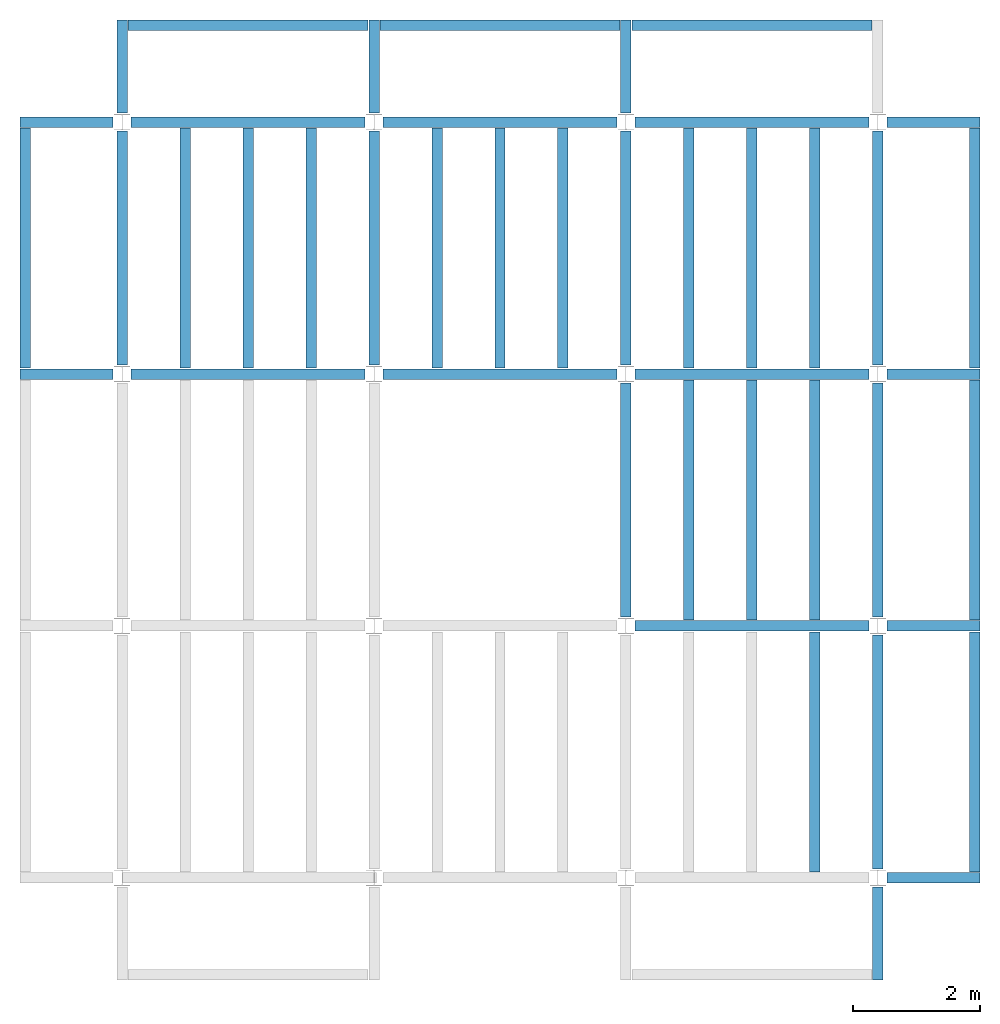
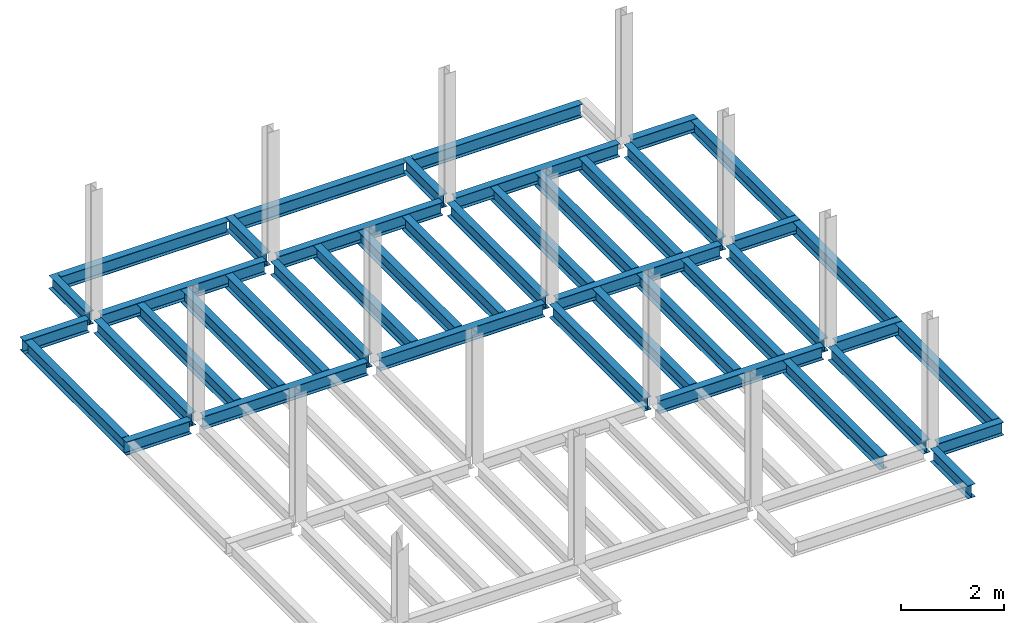
# One storey, part 2 of 3: 44 beams, 5 elements without a shape of their own.
"""IFC4 building model written with IfcOpenShell, lengths in feet."""

from ifc_helpers import new_model, entity, si_unit, converted_unit, derived_unit, direction, frame, origin, place, context, subcontext, project, spatial, line, arc, indexed_curve, outline, extrude, source, transform, mapped, material, type_object, type_shapes, element, aggregate, save


model = new_model("IFC4")

# Units and contexts
model_context = context("Model", 3, precision=0.0001, world=origin(), true_north=direction((6.123233995736766e-17, 1.0)))
plan_context = context("Plan", 3, precision=0.0001, world=origin(), true_north=direction((6.123233995736766e-17, 1.0)))
body_context = subcontext(model_context, "Body", "Model", "MODEL_VIEW")
ifc_project = project(units=[converted_unit("LENGTHUNIT", "FOOT", entity("IfcLengthMeasure", 0.3048), si_unit("LENGTHUNIT", "METRE"), dimensions=[1, 0, 0, 0, 0, 0, 0]), converted_unit("AREAUNIT", "SQUARE FOOT", entity("IfcAreaMeasure", 0.09290304), si_unit("AREAUNIT", "SQUARE_METRE"), dimensions=[2, 0, 0, 0, 0, 0, 0]), converted_unit("PLANEANGLEUNIT", "DEGREE", entity("IfcPlaneAngleMeasure", 0.017453292519943278), si_unit("PLANEANGLEUNIT", "RADIAN"), dimensions=[0, 0, 0, 0, 0, 0, 0]), converted_unit("VOLUMEUNIT", "CUBIC FOOT", entity("IfcVolumeMeasure", 0.028316846592000004), si_unit("VOLUMEUNIT", "CUBIC_METRE"), dimensions=[3, 0, 0, 0, 0, 0, 0]), si_unit("PRESSUREUNIT", "PASCAL"), derived_unit("MASSDENSITYUNIT", [(si_unit("MASSUNIT", "GRAM", prefix="KILO"), 1), (si_unit("LENGTHUNIT", "METRE"), -3)]), derived_unit("VAPORPERMEABILITYUNIT", [(si_unit("LENGTHUNIT", "METRE"), -1), (si_unit("TIMEUNIT", "SECOND"), 1)]), derived_unit("USERDEFINED", [(si_unit("MASSUNIT", "GRAM", prefix="KILO"), 1), (si_unit("LENGTHUNIT", "METRE"), 3), (si_unit("TIMEUNIT", "SECOND"), -3), (si_unit("ELECTRICCURRENTUNIT", "AMPERE"), -2)]), derived_unit("MODULUSOFELASTICITYUNIT", [(si_unit("MASSUNIT", "GRAM", prefix="KILO"), 1), (si_unit("LENGTHUNIT", "METRE"), -1), (si_unit("TIMEUNIT", "SECOND"), -2)]), derived_unit("THERMALEXPANSIONCOEFFICIENTUNIT", [(si_unit("THERMODYNAMICTEMPERATUREUNIT", "KELVIN"), -1)]), derived_unit("SPECIFICHEATCAPACITYUNIT", [(si_unit("TIMEUNIT", "SECOND"), -2), (si_unit("THERMODYNAMICTEMPERATUREUNIT", "KELVIN"), -1), (si_unit("LENGTHUNIT", "METRE"), 2)]), derived_unit("THERMALCONDUCTANCEUNIT", [(si_unit("MASSUNIT", "GRAM", prefix="KILO"), 1), (si_unit("TIMEUNIT", "SECOND"), -3), (si_unit("THERMODYNAMICTEMPERATUREUNIT", "KELVIN"), -1), (si_unit("LENGTHUNIT", "METRE"), 1)])], contexts=[model_context, plan_context])

# Site, building, storey
site_placement = place(None, origin())
site = spatial("IfcSite", under=ifc_project, at=site_placement, CompositionType="ELEMENT")
building_placement = place(site_placement, origin())
building = spatial("IfcBuilding", under=site, at=building_placement, CompositionType="ELEMENT")
storey_placement = place(building_placement, frame((0.0, 0.0, 29.875)))
storey = spatial("IfcBuildingStorey", under=building, at=storey_placement, Name="STR 04", CompositionType="ELEMENT", Elevation=29.875)

# Beams
ifc_material = material(Name="Steel ASTM A992", Category="Metal")
beam_type_1 = type_object("IfcBeamType", Name="W12X26", PredefinedType="JOIST", material=ifc_material)
shared_shape_1 = source(origin(), body_context, "Body", "SweptSolid", [
    extrude(outline(indexed_curve([(-0.27041666666666714, -0.47666666666666574), (-0.27041666666666714, -0.5083333333333351), (0.2704166666666669, -0.5083333333333351), (0.2704166666666669, -0.47666666666666574), (0.03458333333333309, -0.47666666666666574), (0.016905663803669493, -0.46934433619632937), (0.009583333333333202, -0.4516666666666659), (0.0095833333333332, 0.45166666666666705), (0.01690566380366948, 0.4693443361963307), (0.03458333333333325, 0.4766666666666671), (0.2704166666666669, 0.4766666666666671), (0.2704166666666669, 0.5083333333333312), (-0.2704166666666655, 0.5083333333333312), (-0.2704166666666655, 0.4766666666666671), (-0.034583333333333514, 0.47666666666666707), (-0.016905663803669865, 0.46934433619633054), (-0.009583333333333737, 0.45166666666666694), (-0.009583333333333735, -0.4516666666666658), (-0.01690566380367013, -0.4693443361963295), (-0.03458333333333368, -0.47666666666666574)], segments=[line(1, 2, 3, 4, 5), arc(5, 6, 7), line(7, 8), arc(8, 9, 10), line(10, 11, 12, 13, 14, 15), arc(15, 16, 17), line(17, 18), arc(18, 19, 20), line(20, 1)], self_intersect=False)), frame((-6.103346456692914, 0.0, 0.0), z_axis=(-1.0, 0.0, 0.0), x_axis=(0.0, -1.0, 0.0)), (0.0, 0.0, -1.0), 12.083333333333323),
])
type_shapes(beam_type_1, [shared_shape_1])
for number, where, name in (
    (1, (6.561679790026307, 39.0, -0.5083333333333329), "W12X26"),
    (2, (6.561679790026288, 26.0, -0.5083333333333329), "W12X26"),
):
    element("IfcBeam", number, at=place(storey_placement, frame(where)), inside=storey, type_object=beam_type_1, material=ifc_material, Name=name, ObjectType="W Shapes:W12X26", PredefinedType="JOIST", context=body_context, shape_type="MappedRepresentation", body=[
        mapped(shared_shape_1, transform((0.0, 0.0, 0.0), scale=1.0)),
    ])
beam_1_placement = place(storey_placement, frame((39.0, 6.56167979002612, -0.5083333333333329), z_axis=(0.0, 0.0, 1.0), x_axis=(0.0, 1.0, 0.0)))
element("IfcBeam", 3, at=beam_1_placement, inside=storey, type_object=beam_type_1, material=ifc_material, Name="W12X26", ObjectType="W Shapes:W12X26", PredefinedType="JOIST", context=body_context, shape_type="MappedRepresentation", body=[
    mapped(shared_shape_1, transform((0.0, 0.0, 0.0), scale=1.0)),
])
beam_type_2 = type_object("IfcBeamType", Name="W12X26", PredefinedType="JOIST", material=ifc_material)
shared_shape_2 = source(origin(), body_context, "Body", "SweptSolid", [
    extrude(outline(indexed_curve([(-0.27041666666666714, -0.47666666666666574), (-0.27041666666666714, -0.5083333333333351), (0.2704166666666669, -0.5083333333333351), (0.2704166666666669, -0.47666666666666574), (0.03458333333333309, -0.47666666666666574), (0.016905663803669493, -0.46934433619632937), (0.009583333333333202, -0.4516666666666659), (0.0095833333333332, 0.45166666666666705), (0.01690566380366948, 0.4693443361963307), (0.03458333333333325, 0.4766666666666671), (0.2704166666666669, 0.4766666666666671), (0.2704166666666669, 0.5083333333333312), (-0.2704166666666655, 0.5083333333333312), (-0.2704166666666655, 0.4766666666666671), (-0.034583333333333514, 0.47666666666666707), (-0.016905663803669865, 0.46934433619633054), (-0.009583333333333737, 0.45166666666666694), (-0.009583333333333735, -0.4516666666666658), (-0.01690566380367013, -0.4693443361963295), (-0.03458333333333368, -0.47666666666666574)], segments=[line(1, 2, 3, 4, 5), arc(5, 6, 7), line(7, 8), arc(8, 9, 10), line(10, 11, 12, 13, 14, 15), arc(15, 16, 17), line(17, 18), arc(18, 19, 20), line(20, 1)], self_intersect=False)), frame((-6.226706036745409, 0.0, 0.0), z_axis=(-1.0, 0.0, 0.0), x_axis=(0.0, -1.0, 0.0)), (0.0, 0.0, -1.0), 12.08333333333333),
])
type_shapes(beam_type_2, [shared_shape_2])
for number, where, name in (
    (4, (19.685039370078798, 39.0, -0.5083333333333329), "W12X26"),
    (5, (19.68503937007878, 26.0, -0.5083333333333329), "W12X26"),
):
    element("IfcBeam", number, at=place(storey_placement, frame(where)), inside=storey, type_object=beam_type_2, material=ifc_material, Name=name, ObjectType="W Shapes:W12X26", PredefinedType="JOIST", context=body_context, shape_type="MappedRepresentation", body=[
        mapped(shared_shape_2, transform((0.0, 0.0, 0.0), scale=1.0)),
    ])
for number, where, z_axis, x_axis, name in (
    (6, (39.0, 19.685039370078613, -0.5083333333333329), (0.0, 0.0, 1.0), (0.0, 1.0, 0.0), "W12X26"),
    (7, (26.0, 19.685039370078655, -0.5083333333333329), (0.0, 0.0, 1.0), (0.0, 1.0, 0.0), "W12X26"),
):
    element("IfcBeam", number, at=place(storey_placement, frame(where, z_axis=z_axis, x_axis=x_axis)), inside=storey, type_object=beam_type_2, material=ifc_material, Name=name, ObjectType="W Shapes:W12X26", PredefinedType="JOIST", context=body_context, shape_type="MappedRepresentation", body=[
        mapped(shared_shape_2, transform((0.0, 0.0, 0.0), scale=1.0)),
    ])

# Assembly, beams
assembly_1_placement = place(storey_placement, origin())
assembly_1 = element("IfcElementAssembly", 8, at=assembly_1_placement, inside=storey, Name="Structural Framing System", ObjectType="Structural Beam System:Structural Framing System", AssemblyPlace="NOTDEFINED", PredefinedType="BEAM_GRID")
beam_type_3 = type_object("IfcBeamType", Name="W12X26", PredefinedType="JOIST", material=ifc_material)
shared_shape_3 = source(origin(), body_context, "Body", "SweptSolid", [
    extrude(outline(indexed_curve([(-0.27041666666666714, -0.47666666666666574), (-0.27041666666666714, -0.5083333333333351), (0.2704166666666669, -0.5083333333333351), (0.2704166666666669, -0.47666666666666574), (0.03458333333333309, -0.47666666666666574), (0.016905663803669493, -0.46934433619632937), (0.009583333333333202, -0.4516666666666659), (0.0095833333333332, 0.45166666666666705), (0.01690566380366948, 0.4693443361963307), (0.03458333333333325, 0.4766666666666671), (0.2704166666666669, 0.4766666666666671), (0.2704166666666669, 0.5083333333333312), (-0.2704166666666655, 0.5083333333333312), (-0.2704166666666655, 0.4766666666666671), (-0.034583333333333514, 0.47666666666666707), (-0.016905663803669865, 0.46934433619633054), (-0.009583333333333737, 0.45166666666666694), (-0.009583333333333735, -0.4516666666666658), (-0.01690566380367013, -0.4693443361963295), (-0.03458333333333368, -0.47666666666666574)], segments=[line(1, 2, 3, 4, 5), arc(5, 6, 7), line(7, 8), arc(8, 9, 10), line(10, 11, 12, 13, 14, 15), arc(15, 16, 17), line(17, 18), arc(18, 19, 20), line(20, 1)], self_intersect=False)), frame((-6.187916666666566, 0.0, 0.0), z_axis=(-1.0, 0.0, 0.0), x_axis=(0.0, -1.0, 0.0)), (0.0, 0.0, -1.0), 12.375833333333075),
])
type_shapes(beam_type_3, [shared_shape_3])
beam_2_placement = place(assembly_1_placement, frame((3.250000000000073, 32.49999999999969, -0.5083333333333329), z_axis=(0.0, 0.0, 1.0), x_axis=(0.0, 1.0, 0.0)))
beam_2 = element("IfcBeam", 9, at=beam_2_placement, type_object=beam_type_3, material=ifc_material, Name="W12X26", ObjectType="W Shapes:W12X26", PredefinedType="JOIST", context=body_context, shape_type="MappedRepresentation", body=[
    mapped(shared_shape_3, transform((0.0, 0.0, 0.0), scale=1.0)),
])
beam_3_placement = place(assembly_1_placement, frame((6.500000000000094, 32.49999999999967, -0.5083333333333329), z_axis=(0.0, 0.0, 1.0), x_axis=(0.0, 1.0, 0.0)))
beam_3 = element("IfcBeam", 10, at=beam_3_placement, type_object=beam_type_3, material=ifc_material, Name="W12X26", ObjectType="W Shapes:W12X26", PredefinedType="JOIST", context=body_context, shape_type="MappedRepresentation", body=[
    mapped(shared_shape_3, transform((0.0, 0.0, 0.0), scale=1.0)),
])
beam_4_placement = place(assembly_1_placement, frame((9.750000000000115, 32.49999999999966, -0.5083333333333329), z_axis=(0.0, 0.0, 1.0), x_axis=(0.0, 1.0, 0.0)))
beam_4 = element("IfcBeam", 11, at=beam_4_placement, type_object=beam_type_3, material=ifc_material, Name="W12X26", ObjectType="W Shapes:W12X26", PredefinedType="JOIST", context=body_context, shape_type="MappedRepresentation", body=[
    mapped(shared_shape_3, transform((0.0, 0.0, 0.0), scale=1.0)),
])
aggregate(assembly_1, [beam_2, beam_3, beam_4])

assembly_2_placement = place(storey_placement, origin())
assembly_2 = element("IfcElementAssembly", 12, at=assembly_2_placement, inside=storey, Name="Structural Framing System", ObjectType="Structural Beam System:Structural Framing System", AssemblyPlace="NOTDEFINED", PredefinedType="BEAM_GRID")
beam_5_placement = place(assembly_2_placement, frame((16.25000000000014, 32.499999999999645, -0.5083333333333329), z_axis=(0.0, 0.0, 1.0), x_axis=(0.0, 1.0, 0.0)))
beam_5 = element("IfcBeam", 13, at=beam_5_placement, type_object=beam_type_3, material=ifc_material, Name="W12X26", ObjectType="W Shapes:W12X26", PredefinedType="JOIST", context=body_context, shape_type="MappedRepresentation", body=[
    mapped(shared_shape_3, transform((0.0, 0.0, 0.0), scale=1.0)),
])
beam_6_placement = place(assembly_2_placement, frame((19.50000000000014, 32.49999999999963, -0.5083333333333329), z_axis=(0.0, 0.0, 1.0), x_axis=(0.0, 1.0, 0.0)))
beam_6 = element("IfcBeam", 14, at=beam_6_placement, type_object=beam_type_3, material=ifc_material, Name="W12X26", ObjectType="W Shapes:W12X26", PredefinedType="JOIST", context=body_context, shape_type="MappedRepresentation", body=[
    mapped(shared_shape_3, transform((0.0, 0.0, 0.0), scale=1.0)),
])
beam_7_placement = place(assembly_2_placement, frame((22.750000000000142, 32.499999999999616, -0.5083333333333329), z_axis=(0.0, 0.0, 1.0), x_axis=(0.0, 1.0, 0.0)))
beam_7 = element("IfcBeam", 15, at=beam_7_placement, type_object=beam_type_3, material=ifc_material, Name="W12X26", ObjectType="W Shapes:W12X26", PredefinedType="JOIST", context=body_context, shape_type="MappedRepresentation", body=[
    mapped(shared_shape_3, transform((0.0, 0.0, 0.0), scale=1.0)),
])
aggregate(assembly_2, [beam_5, beam_6, beam_7])

# Assembly, beam
assembly_3_placement = place(storey_placement, origin())
assembly_3 = element("IfcElementAssembly", 16, at=assembly_3_placement, inside=storey, Name="Structural Framing System", ObjectType="Structural Beam System:Structural Framing System", AssemblyPlace="NOTDEFINED", PredefinedType="BEAM_GRID")
beam_8_placement = place(assembly_3_placement, frame((35.7500000000001, 6.499999999999728, -0.5083333333333329), z_axis=(0.0, 0.0, 1.0), x_axis=(0.0, 1.0, 0.0)))
beam_8 = element("IfcBeam", 17, at=beam_8_placement, type_object=beam_type_3, material=ifc_material, Name="W12X26", ObjectType="W Shapes:W12X26", PredefinedType="JOIST", context=body_context, shape_type="MappedRepresentation", body=[
    mapped(shared_shape_3, transform((0.0, 0.0, 0.0), scale=1.0)),
])
aggregate(assembly_3, [beam_8])

# Assembly, beams
assembly_4_placement = place(storey_placement, origin())
assembly_4 = element("IfcElementAssembly", 18, at=assembly_4_placement, inside=storey, Name="Structural Framing System", ObjectType="Structural Beam System:Structural Framing System", AssemblyPlace="NOTDEFINED", PredefinedType="BEAM_GRID")
beam_9_placement = place(assembly_4_placement, frame((29.25000000000012, 19.499999999999595, -0.5083333333333329), z_axis=(0.0, 0.0, 1.0), x_axis=(0.0, 1.0, 0.0)))
beam_9 = element("IfcBeam", 19, at=beam_9_placement, type_object=beam_type_3, material=ifc_material, Name="W12X26", ObjectType="W Shapes:W12X26", PredefinedType="JOIST", context=body_context, shape_type="MappedRepresentation", body=[
    mapped(shared_shape_3, transform((0.0, 0.0, 0.0), scale=1.0)),
])
beam_10_placement = place(assembly_4_placement, frame((32.500000000000114, 19.49999999999958, -0.5083333333333329), z_axis=(0.0, 0.0, 1.0), x_axis=(0.0, 1.0, 0.0)))
beam_10 = element("IfcBeam", 20, at=beam_10_placement, type_object=beam_type_3, material=ifc_material, Name="W12X26", ObjectType="W Shapes:W12X26", PredefinedType="JOIST", context=body_context, shape_type="MappedRepresentation", body=[
    mapped(shared_shape_3, transform((0.0, 0.0, 0.0), scale=1.0)),
])
beam_11_placement = place(assembly_4_placement, frame((35.750000000000114, 19.499999999999574, -0.5083333333333329), z_axis=(0.0, 0.0, 1.0), x_axis=(0.0, 1.0, 0.0)))
beam_11 = element("IfcBeam", 21, at=beam_11_placement, type_object=beam_type_3, material=ifc_material, Name="W12X26", ObjectType="W Shapes:W12X26", PredefinedType="JOIST", context=body_context, shape_type="MappedRepresentation", body=[
    mapped(shared_shape_3, transform((0.0, 0.0, 0.0), scale=1.0)),
])
aggregate(assembly_4, [beam_9, beam_10, beam_11])

assembly_5_placement = place(storey_placement, origin())
assembly_5 = element("IfcElementAssembly", 22, at=assembly_5_placement, inside=storey, Name="Structural Framing System", ObjectType="Structural Beam System:Structural Framing System", AssemblyPlace="NOTDEFINED", PredefinedType="BEAM_GRID")
beam_12_placement = place(assembly_5_placement, frame((29.250000000000142, 32.4999999999996, -0.5083333333333329), z_axis=(0.0, 0.0, 1.0), x_axis=(0.0, 1.0, 0.0)))
beam_12 = element("IfcBeam", 23, at=beam_12_placement, type_object=beam_type_3, material=ifc_material, Name="W12X26", ObjectType="W Shapes:W12X26", PredefinedType="JOIST", context=body_context, shape_type="MappedRepresentation", body=[
    mapped(shared_shape_3, transform((0.0, 0.0, 0.0), scale=1.0)),
])
beam_13_placement = place(assembly_5_placement, frame((32.50000000000014, 32.49999999999959, -0.5083333333333329), z_axis=(0.0, 0.0, 1.0), x_axis=(0.0, 1.0, 0.0)))
beam_13 = element("IfcBeam", 24, at=beam_13_placement, type_object=beam_type_3, material=ifc_material, Name="W12X26", ObjectType="W Shapes:W12X26", PredefinedType="JOIST", context=body_context, shape_type="MappedRepresentation", body=[
    mapped(shared_shape_3, transform((0.0, 0.0, 0.0), scale=1.0)),
])
beam_14_placement = place(assembly_5_placement, frame((35.75000000000014, 32.499999999999574, -0.5083333333333329), z_axis=(0.0, 0.0, 1.0), x_axis=(0.0, 1.0, 0.0)))
beam_14 = element("IfcBeam", 25, at=beam_14_placement, type_object=beam_type_3, material=ifc_material, Name="W12X26", ObjectType="W Shapes:W12X26", PredefinedType="JOIST", context=body_context, shape_type="MappedRepresentation", body=[
    mapped(shared_shape_3, transform((0.0, 0.0, 0.0), scale=1.0)),
])
aggregate(assembly_5, [beam_12, beam_13, beam_14])

# Beams
for number, where, z_axis, x_axis, name in (
    (26, (-5.0, 32.4999999999997, -0.5083333333333329), (0.0, 0.0, 1.0), (0.0, 1.0, 0.0), "W12X26"),
    (27, (44.0, 6.4999999999997, -0.5083333333333329), (0.0, 0.0, 1.0), (0.0, 1.0, 0.0), "W12X26"),
    (28, (44.0, 19.499999999999545, -0.5083333333333329), (0.0, 0.0, 1.0), (0.0, 1.0, 0.0), "W12X26"),
    (29, (44.0, 32.499999999999545, -0.5083333333333329), (0.0, 0.0, 1.0), (0.0, 1.0, 0.0), "W12X26"),
):
    element("IfcBeam", number, at=place(storey_placement, frame(where, z_axis=z_axis, x_axis=x_axis)), inside=storey, type_object=beam_type_3, material=ifc_material, Name=name, ObjectType="W Shapes:W12X26", PredefinedType="JOIST", context=body_context, shape_type="MappedRepresentation", body=[
        mapped(shared_shape_3, transform((0.0, 0.0, 0.0), scale=1.0)),
    ])
beam_15_placement = place(storey_placement, frame((6.5000000000001625, 44.0, -0.5083333333333329)))
element("IfcBeam", 30, at=beam_15_placement, inside=storey, type_object=beam_type_3, material=ifc_material, Name="W Shapes:W12X26", ObjectType="W Shapes:W12X26", PredefinedType="JOIST", context=body_context, shape_type="MappedRepresentation", body=[
    mapped(shared_shape_3, transform((0.0, 0.0, 0.0), scale=1.0)),
])
beam_type_4 = type_object("IfcBeamType", Name="W12X26", PredefinedType="JOIST", material=ifc_material)
shared_shape_4 = source(origin(), body_context, "Body", "SweptSolid", [
    extrude(outline(indexed_curve([(-0.27041666666666714, -0.47666666666666574), (-0.27041666666666714, -0.5083333333333351), (0.2704166666666669, -0.5083333333333351), (0.2704166666666669, -0.47666666666666574), (0.03458333333333309, -0.47666666666666574), (0.016905663803669493, -0.46934433619632937), (0.009583333333333202, -0.4516666666666659), (0.0095833333333332, 0.45166666666666705), (0.01690566380366948, 0.4693443361963307), (0.03458333333333325, 0.4766666666666671), (0.2704166666666669, 0.4766666666666671), (0.2704166666666669, 0.5083333333333312), (-0.2704166666666655, 0.5083333333333312), (-0.2704166666666655, 0.4766666666666671), (-0.034583333333333514, 0.47666666666666707), (-0.016905663803669865, 0.46934433619633054), (-0.009583333333333737, 0.45166666666666694), (-0.009583333333333735, -0.4516666666666658), (-0.01690566380367013, -0.4693443361963295), (-0.03458333333333368, -0.47666666666666574)], segments=[line(1, 2, 3, 4, 5), arc(5, 6, 7), line(7, 8), arc(8, 9, 10), line(10, 11, 12, 13, 14, 15), arc(15, 16, 17), line(17, 18), arc(18, 19, 20), line(20, 1)], self_intersect=False)), frame((-6.165026246719308, 0.0, 0.0), z_axis=(-1.0, 0.0, 0.0), x_axis=(0.0, -1.0, 0.0)), (0.0, 0.0, -1.0), 12.08333333333334),
])
type_shapes(beam_type_4, [shared_shape_4])
for number, where, name in (
    (31, (32.6233595800526, 39.0, -0.5083333333333329), "W12X26"),
    (32, (32.62335958005258, 26.0, -0.5083333333333329), "W12X26"),
    (33, (32.62335958005255, 13.0, -0.5083333333333329), "W12X26"),
):
    element("IfcBeam", number, at=place(storey_placement, frame(where)), inside=storey, type_object=beam_type_4, material=ifc_material, Name=name, ObjectType="W Shapes:W12X26", PredefinedType="JOIST", context=body_context, shape_type="MappedRepresentation", body=[
        mapped(shared_shape_4, transform((0.0, 0.0, 0.0), scale=1.0)),
    ])
for number, where, z_axis, x_axis, name in (
    (34, (39.0, 32.62335958005221, -0.5083333333333329), (0.0, 0.0, 1.0), (0.0, 1.0, 0.0), "W12X26"),
    (35, (26.0, 32.62335958005225, -0.5083333333333329), (0.0, 0.0, 1.0), (0.0, 1.0, 0.0), "W12X26"),
    (36, (13.0, 32.623359580052295, -0.5083333333333329), (0.0, 0.0, 1.0), (0.0, 1.0, 0.0), "W12X26"),
    (37, (0.0, 32.62335958005234, -0.5083333333333329), (0.0, 0.0, 1.0), (0.0, 1.0, 0.0), "W12X26"),
):
    element("IfcBeam", number, at=place(storey_placement, frame(where, z_axis=z_axis, x_axis=x_axis)), inside=storey, type_object=beam_type_4, material=ifc_material, Name=name, ObjectType="W Shapes:W12X26", PredefinedType="JOIST", context=body_context, shape_type="MappedRepresentation", body=[
        mapped(shared_shape_4, transform((0.0, 0.0, 0.0), scale=1.0)),
    ])
beam_type_5 = type_object("IfcBeamType", Name="W12X26", PredefinedType="JOIST", material=ifc_material)
shared_shape_5 = source(origin(), body_context, "Body", "SweptSolid", [
    extrude(outline(indexed_curve([(0.47666666666666574, -0.2704166666666672), (0.5083333333333351, -0.2704166666666672), (0.5083333333333351, 0.27041666666666686), (0.47666666666666574, 0.27041666666666686), (0.47666666666666574, 0.03458333333333307), (0.46934433619632937, 0.016905663803669473), (0.4516666666666659, 0.00958333333333318), (-0.45166666666666705, 0.00958333333333318), (-0.4693443361963307, 0.01690566380366946), (-0.4766666666666671, 0.03458333333333323), (-0.4766666666666671, 0.27041666666666686), (-0.5083333333333312, 0.27041666666666686), (-0.5083333333333312, -0.27041666666666553), (-0.4766666666666671, -0.27041666666666553), (-0.47666666666666707, -0.034583333333333535), (-0.46934433619633054, -0.016905663803669885), (-0.45166666666666694, -0.00958333333333376), (0.4516666666666658, -0.009583333333333756), (0.4693443361963295, -0.01690566380367015), (0.47666666666666574, -0.0345833333333337)], segments=[line(1, 2, 3, 4, 5), arc(5, 6, 7), line(7, 8), arc(8, 9, 10), line(10, 11, 12, 13, 14, 15), arc(15, 16, 17), line(17, 18), arc(18, 19, 20), line(20, 1)], self_intersect=False)), frame((-2.0416666666666208, 0.0, 0.0), z_axis=(1.0, 0.0, 0.0), x_axis=(0.0, 0.0, -1.0)), (0.0, 0.0, 1.0), 4.812083333333336),
])
type_shapes(beam_type_5, [shared_shape_5])
for number, where, z_axis, x_axis, name in (
    (38, (-2.4999999999998104, 39.0, -0.5083333333333329), (0.0, 0.0, 1.0), (-1.0, 0.0, 0.0), "W12X26"),
    (39, (39.0, -2.50000000000058, -0.5083333333333329), (0.0, 0.0, 1.0), (0.0, -1.0, 0.0), "W12X26"),
    (40, (-2.4999999999998317, 26.0, -0.5083333333333329), (0.0, 0.0, 1.0), (-1.0, 0.0, 0.0), "W12X26"),
):
    element("IfcBeam", number, at=place(storey_placement, frame(where, z_axis=z_axis, x_axis=x_axis)), inside=storey, type_object=beam_type_5, material=ifc_material, Name=name, ObjectType="W Shapes:W12X26", PredefinedType="JOIST", context=body_context, shape_type="MappedRepresentation", body=[
        mapped(shared_shape_5, transform((0.0, 0.0, 0.0), scale=1.0)),
    ])
beam_type_6 = type_object("IfcBeamType", Name="W12X26", PredefinedType="JOIST", material=ifc_material)
shared_shape_6 = source(origin(), body_context, "Body", "SweptSolid", [
    extrude(outline(indexed_curve([(0.47666666666666574, -0.2704166666666672), (0.5083333333333351, -0.2704166666666672), (0.5083333333333351, 0.27041666666666686), (0.47666666666666574, 0.27041666666666686), (0.47666666666666574, 0.03458333333333307), (0.46934433619632937, 0.016905663803669473), (0.4516666666666659, 0.00958333333333318), (-0.45166666666666705, 0.00958333333333318), (-0.4693443361963307, 0.01690566380366946), (-0.4766666666666671, 0.03458333333333323), (-0.4766666666666671, 0.27041666666666686), (-0.5083333333333312, 0.27041666666666686), (-0.5083333333333312, -0.27041666666666553), (-0.4766666666666671, -0.27041666666666553), (-0.47666666666666707, -0.034583333333333535), (-0.46934433619633054, -0.016905663803669885), (-0.45166666666666694, -0.00958333333333376), (0.4516666666666658, -0.009583333333333756), (0.4693443361963295, -0.01690566380367015), (0.47666666666666574, -0.0345833333333337)], segments=[line(1, 2, 3, 4, 5), arc(5, 6, 7), line(7, 8), arc(8, 9, 10), line(10, 11, 12, 13, 14, 15), arc(15, 16, 17), line(17, 18), arc(18, 19, 20), line(20, 1)], self_intersect=False)), frame((-2.77041666666672, 0.0, 0.0), z_axis=(1.0, 0.0, 0.0), x_axis=(0.0, 0.0, -1.0)), (0.0, 0.0, 1.0), 4.812083333333389),
])
type_shapes(beam_type_6, [shared_shape_6])
for number, where, z_axis, x_axis, name in (
    (41, (41.50000000000013, 26.0, -0.5083333333333329), (0.0, 0.0, 1.0), (-1.0, 0.0, 0.0), "W12X26"),
    (42, (41.50000000000011, 13.0, -0.5083333333333329), (0.0, 0.0, 1.0), (-1.0, 0.0, 0.0), "W12X26"),
    (43, (41.500000000000085, 0.0, -0.5083333333333329), (0.0, 0.0, 1.0), (-1.0, 0.0, 0.0), "W12X26"),
    (44, (13.0, 41.49999999999965, -0.5083333333333329), (0.0, 0.0, 1.0), (0.0, -1.0, 0.0), "W12X26"),
    (45, (0.0, 41.499999999999694, -0.5083333333333329), (0.0, 0.0, 1.0), (0.0, -1.0, 0.0), "W12X26"),
    (46, (41.50000000000015, 39.0, -0.5083333333333329), (0.0, 0.0, 1.0), (-1.0, 0.0, 0.0), "W12X26"),
):
    element("IfcBeam", number, at=place(storey_placement, frame(where, z_axis=z_axis, x_axis=x_axis)), inside=storey, type_object=beam_type_6, material=ifc_material, Name=name, ObjectType="W Shapes:W12X26", PredefinedType="JOIST", context=body_context, shape_type="MappedRepresentation", body=[
        mapped(shared_shape_6, transform((0.0, 0.0, 0.0), scale=1.0)),
    ])
beam_type_7 = type_object("IfcBeamType", Name="W12X26", PredefinedType="JOIST", material=ifc_material)
shared_shape_7 = source(origin(), body_context, "Body", "SweptSolid", [
    extrude(outline(indexed_curve([(0.47666666666666574, -0.2704166666666672), (0.5083333333333351, -0.2704166666666672), (0.5083333333333351, 0.27041666666666686), (0.47666666666666574, 0.27041666666666686), (0.47666666666666574, 0.03458333333333307), (0.46934433619632937, 0.016905663803669473), (0.4516666666666659, 0.00958333333333318), (-0.45166666666666705, 0.00958333333333318), (-0.4693443361963307, 0.01690566380366946), (-0.4766666666666671, 0.03458333333333323), (-0.4766666666666671, 0.27041666666666686), (-0.5083333333333312, 0.27041666666666686), (-0.5083333333333312, -0.27041666666666553), (-0.4766666666666671, -0.27041666666666553), (-0.47666666666666707, -0.034583333333333535), (-0.46934433619633054, -0.016905663803669885), (-0.45166666666666694, -0.00958333333333376), (0.4516666666666658, -0.009583333333333756), (0.4693443361963295, -0.01690566380367015), (0.47666666666666574, -0.0345833333333337)], segments=[line(1, 2, 3, 4, 5), arc(5, 6, 7), line(7, 8), arc(8, 9, 10), line(10, 11, 12, 13, 14, 15), arc(15, 16, 17), line(17, 18), arc(18, 19, 20), line(20, 1)], self_intersect=False)), frame((-6.187916666666685, 0.0, 0.0), z_axis=(1.0, 0.0, 0.0), x_axis=(0.0, 0.0, -1.0)), (0.0, 0.0, 1.0), 12.375833333333318),
])
type_shapes(beam_type_7, [shared_shape_7])
beam_16_placement = place(storey_placement, frame((19.500000000000142, 44.0, -0.5083333333333329), z_axis=(0.0, 0.0, 1.0), x_axis=(-1.0, 0.0, 0.0)))
element("IfcBeam", 47, at=beam_16_placement, inside=storey, type_object=beam_type_7, material=ifc_material, Name="W Shapes:W12X26", ObjectType="W Shapes:W12X26", PredefinedType="JOIST", context=body_context, shape_type="MappedRepresentation", body=[
    mapped(shared_shape_7, transform((0.0, 0.0, 0.0), scale=1.0)),
])
beam_type_8 = type_object("IfcBeamType", Name="W12X26", PredefinedType="JOIST", material=ifc_material)
shared_shape_8 = source(origin(), body_context, "Body", "SweptSolid", [
    extrude(outline(indexed_curve([(-0.2704166666666694, -0.5083333333333364), (0.27041666666666586, -0.5083333333333364), (0.2704166666666623, -0.4766666666666737), (0.034583333333333854, -0.4766666666666701), (0.016905663803669313, -0.4693443361963361), (0.009583333333335275, -0.45166666666667155), (0.009583333333335275, 0.4516666666666609), (0.016905663803669313, 0.46934433619632543), (0.034583333333333854, 0.47666666666665947), (0.2704166666666694, 0.47666666666665947), (0.27041666666666586, 0.5083333333333293), (-0.27041666666666586, 0.5083333333333293), (-0.27041666666666586, 0.47666666666665947), (-0.0345833333333303, 0.47666666666665947), (-0.01690566380366576, 0.46934433619632543), (-0.009583333333331723, 0.4516666666666609), (-0.009583333333331723, -0.45166666666667155), (-0.01690566380366576, -0.4693443361963361), (-0.034583333333333854, -0.4766666666666737), (-0.27041666666666586, -0.4766666666666737)], segments=[line(1, 2, 3, 4), arc(4, 5, 6), line(6, 7), arc(7, 8, 9), line(9, 10, 11, 12, 13, 14), arc(14, 15, 16), line(16, 17), arc(17, 18, 19), line(19, 20, 1)], self_intersect=False)), frame((26.0, 44.27041666666632, 29.366666666666646), z_axis=(0.0, -1.0, 0.0), x_axis=(-1.0, 0.0, 0.0)), (0.0, 0.0, 1.0), 4.812083333333393),
])
type_shapes(beam_type_8, [shared_shape_8])
beam_17_placement = place(storey_placement, frame((0.0, 0.0, -29.875)))
element("IfcBeam", 48, at=beam_17_placement, inside=storey, type_object=beam_type_8, material=ifc_material, Name="W12X26", ObjectType="W Shapes:W12X26", PredefinedType="JOIST", context=body_context, shape_type="MappedRepresentation", body=[
    mapped(shared_shape_8, transform((0.0, 0.0, 0.0), scale=1.0)),
])
beam_type_9 = type_object("IfcBeamType", Name="W12X26", PredefinedType="JOIST", material=ifc_material)
shared_shape_9 = source(origin(), body_context, "Body", "SweptSolid", [
    extrude(outline(indexed_curve([(-0.5083333333333329, -0.2704166666666694), (-0.4766666666666701, -0.2704166666666694), (-0.47666666666666657, -0.03458333333333741), (-0.46934433619633253, -0.01690566380367642), (-0.451666666666668, -0.009583333333338828), (0.45166666666666444, -0.009583333333338828), (0.469344336196329, -0.01690566380367642), (0.476666666666663, -0.03458333333333741), (0.476666666666663, -0.2704166666666694), (0.5083333333333329, -0.2704166666666694), (0.5083333333333329, 0.2704166666666623), (0.476666666666663, 0.2704166666666623), (0.476666666666663, 0.0345833333333303), (0.469344336196329, 0.016905663803669313), (0.45166666666666444, 0.009583333333331723), (-0.451666666666668, 0.009583333333331723), (-0.469344336196329, 0.016905663803669313), (-0.4766666666666701, 0.0345833333333303), (-0.4766666666666701, 0.2704166666666623), (-0.5083333333333329, 0.2704166666666623)], segments=[line(1, 2, 3), arc(3, 4, 5), line(5, 6), arc(6, 7, 8), line(8, 9, 10, 11, 12, 13), arc(13, 14, 15), line(15, 16), arc(16, 17, 18), line(18, 19, 20, 1)], self_intersect=False)), frame((26.312083333333604, 44.0, 29.36666666666665), z_axis=(1.0, 0.0, 0.0), x_axis=(0.0, 0.0, -1.0)), (0.0, 0.0, 1.0), 12.375833333333079),
])
type_shapes(beam_type_9, [shared_shape_9])
beam_18_placement = place(storey_placement, frame((0.0, 0.0, -29.875)))
element("IfcBeam", 49, at=beam_18_placement, inside=storey, type_object=beam_type_9, material=ifc_material, Name="W Shapes:W12X26", ObjectType="W Shapes:W12X26", PredefinedType="JOIST", context=body_context, shape_type="MappedRepresentation", body=[
    mapped(shared_shape_9, transform((0.0, 0.0, 0.0), scale=1.0)),
])

save(model, "model.ifc")
